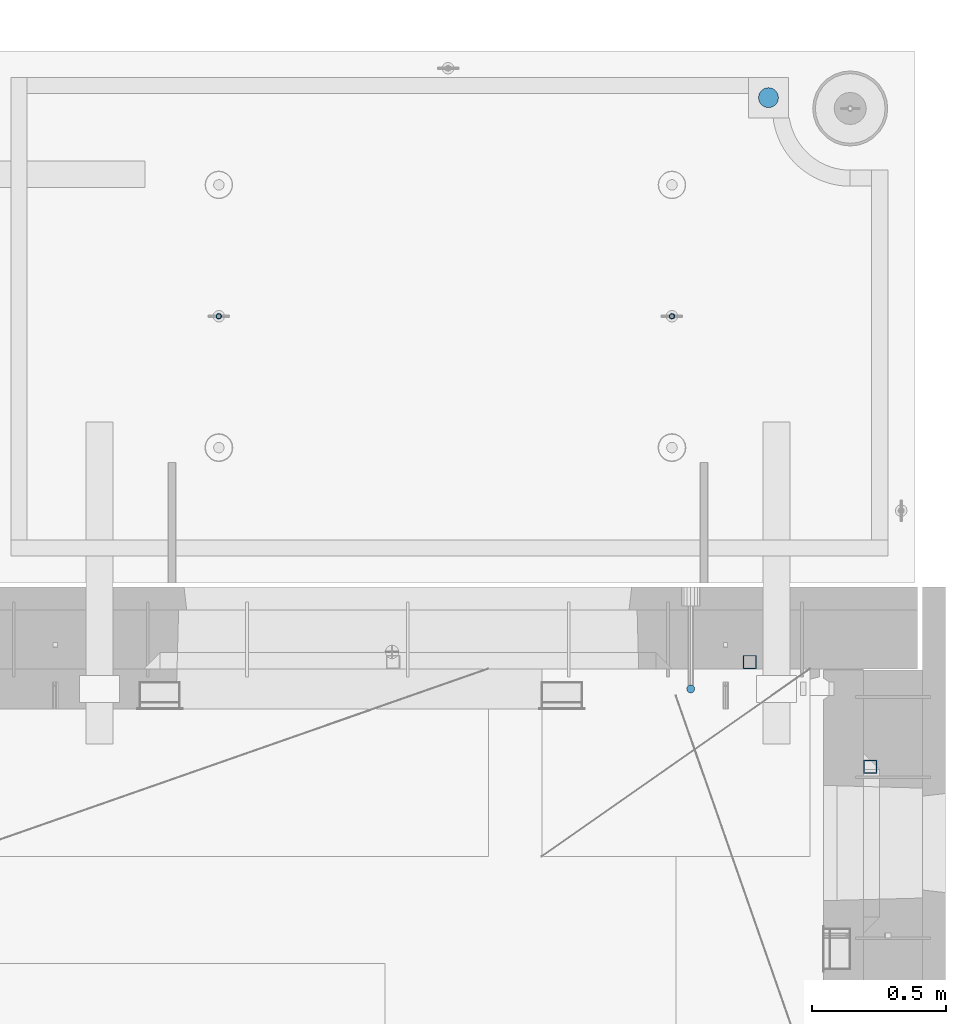
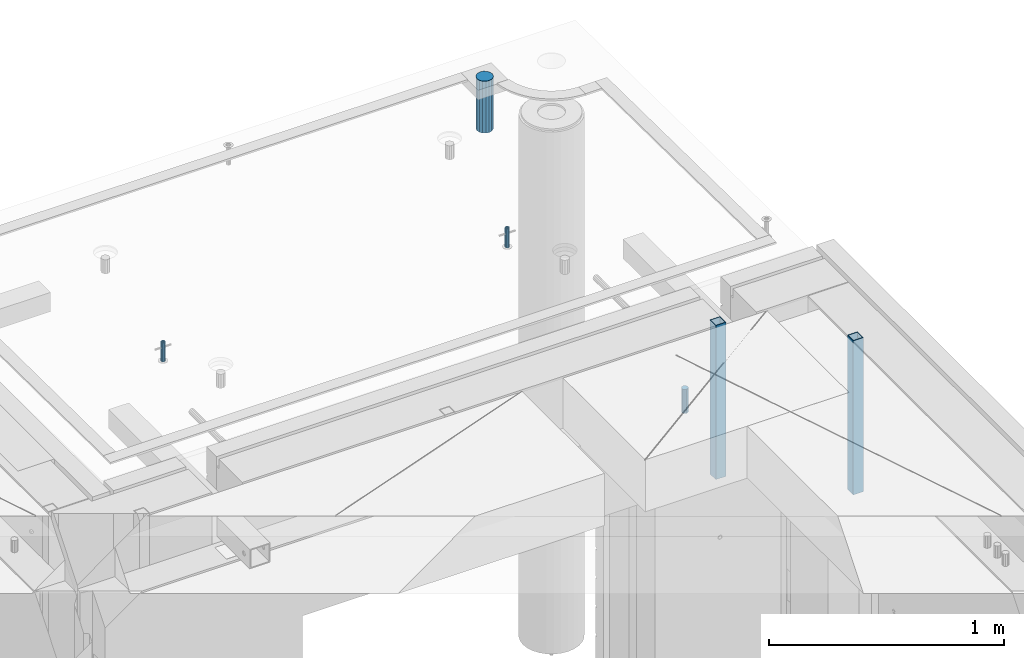
# One storey, part 37 of 349: 6 columns, 7 elements without a shape of their own.
"""IFC2X3 building model written with IfcOpenShell, lengths in millimetres."""

from ifc_helpers import new_model, si_unit, frame, origin_with_axes, place, context, subcontext, project, spatial, faceted_brep, material, type_object, element, aggregate, save


model = new_model("IFC2X3")

# Units and contexts
model_context = context("Model", 3, precision=1e-05, world=origin_with_axes())
body_context = subcontext(model_context, "Body", "Model", "MODEL_VIEW")
ifc_project = project(units=[si_unit("LENGTHUNIT", "METRE", prefix="MILLI"), si_unit("AREAUNIT", "SQUARE_METRE"), si_unit("VOLUMEUNIT", "CUBIC_METRE"), si_unit("MASSUNIT", "GRAM", prefix="KILO"), si_unit("TIMEUNIT", "SECOND"), si_unit("PLANEANGLEUNIT", "RADIAN"), si_unit("SOLIDANGLEUNIT", "STERADIAN"), si_unit("THERMODYNAMICTEMPERATUREUNIT", "DEGREE_CELSIUS"), si_unit("LUMINOUSINTENSITYUNIT", "LUMEN")], contexts=[model_context])

# Site, building, storey
site_placement = place(None, origin_with_axes())
site = spatial("IfcSite", under=ifc_project, at=site_placement, CompositionType="ELEMENT")
building_placement = place(site_placement, origin_with_axes())
building = spatial("IfcBuilding", under=site, at=building_placement, CompositionType="ELEMENT")
storey_placement = place(building_placement, origin_with_axes())
storey = spatial("IfcBuildingStorey", under=building, at=storey_placement, Name="4", CompositionType="ELEMENT", Elevation=0.0)

# Assemblies, columns
assembly_1_placement = place(storey_placement, origin_with_axes())
assembly_1 = element("IfcElementAssembly", 1, at=assembly_1_placement, inside=storey, AssemblyPlace="NOTDEFINED", PredefinedType="REINFORCEMENT_UNIT")
ifc_material_1 = material()
column_type_1 = type_object("IfcColumnType", Name="D30", PredefinedType="NOTDEFINED")
column_1_placement = place(assembly_1_placement, frame((34415.0073334623, 20504.9951872205, 93407.5), z_axis=(0.0, -1.0, 0.0), x_axis=(0.0, 0.0, 1.0)))
column_1 = element("IfcColumn", 2, at=column_1_placement, type_object=column_type_1, material=ifc_material_1, ObjectType="D30", context=body_context, shape_type="Brep", body=[
    faceted_brep([(0.0, -15.0, 0.0), (0.0, -12.9903810567666, -7.5), (125.0, -12.9903810567666, -7.5), (125.0, -15.0, 0.0), (0.0, -7.5, -12.9903810567666), (125.0, -7.5, -12.9903810567666), (0.0, 0.0, -15.0), (125.0, 0.0, -15.0), (0.0, 7.5, -12.9903810567666), (125.0, 7.5, -12.9903810567666), (0.0, 12.9903810567666, -7.5), (125.0, 12.9903810567666, -7.5), (0.0, 15.0, 0.0), (125.0, 15.0, 0.0), (0.0, 12.9903810567666, 7.5), (125.0, 12.9903810567666, 7.5), (0.0, 7.5, 12.9903810567666), (125.0, 7.5, 12.9903810567666), (0.0, 0.0, 15.0), (125.0, 0.0, 15.0), (0.0, -7.5, 12.9903810567666), (125.0, -7.5, 12.9903810567666), (0.0, -12.9903810567666, 7.5), (125.0, -12.9903810567666, 7.5)], [[[0, 1, 2, 3]], [[1, 4, 5, 2]], [[4, 6, 7, 5]], [[6, 8, 9, 7]], [[8, 10, 11, 9]], [[10, 12, 13, 11]], [[12, 14, 15, 13]], [[14, 16, 17, 15]], [[16, 18, 19, 17]], [[18, 20, 21, 19]], [[20, 22, 23, 21]], [[22, 0, 3, 23]], [[5, 7, 9, 11, 13, 15, 17, 19, 21, 23, 3, 2]], [[22, 20, 18, 16, 14, 12, 10, 8, 6, 4, 1, 0]]]),
])
assembly_2_placement = place(assembly_1_placement, origin_with_axes())
assembly_2 = element("IfcElementAssembly", 3, at=assembly_2_placement, Name="Steel Assembly", AssemblyPlace="NOTDEFINED", PredefinedType="RIGID_FRAME")
aggregate(assembly_1, [assembly_2, column_1])
ifc_material_2 = material(Name="STEEL/S355J2")
column_type_2 = type_object("IfcColumnType", Name="50X50X3", PredefinedType="NOTDEFINED")
column_2_placement = place(assembly_2_placement, frame((34635.0, 20605.0, 92940.0), z_axis=(1.0, 0.0, 0.0), x_axis=(0.0, 0.0, 1.0)))
column_2 = element("IfcColumn", 4, at=column_2_placement, type_object=column_type_2, material=ifc_material_2, ObjectType="50X50X3", context=body_context, shape_type="Brep", body=[
    faceted_brep([(0.0, 22.0, -22.0), (0.0, -22.0, -22.0), (800.0, -22.0, -22.0), (800.0, 22.0, -22.0), (0.0, -22.0, 22.0), (800.0, -22.0, 22.0), (0.0, 22.0, 22.0), (800.0, 22.0, 22.0), (0.0, 25.0, -25.0), (0.0, 25.0, 25.0), (800.0, 25.0, 25.0), (800.0, 25.0, -25.0), (0.0, -25.0, 25.0), (800.0, -25.0, 25.0), (0.0, -25.0, -25.0), (800.0, -25.0, -25.0)], [[[0, 1, 2, 3]], [[1, 4, 5, 2]], [[4, 6, 7, 5]], [[6, 0, 3, 7]], [[8, 9, 10, 11]], [[9, 12, 13, 10]], [[12, 14, 15, 13]], [[14, 8, 11, 15]], [[13, 15, 11, 10], [5, 7, 3, 2]], [[14, 12, 9, 8], [6, 4, 1, 0]]]),
])
aggregate(assembly_2, [column_2])

# Assemblies, column
assembly_3_placement = place(storey_placement, origin_with_axes())
assembly_3 = element("IfcElementAssembly", 5, at=assembly_3_placement, inside=storey, AssemblyPlace="NOTDEFINED", PredefinedType="REINFORCEMENT_UNIT")
assembly_4_placement = place(assembly_3_placement, origin_with_axes())
assembly_4 = element("IfcElementAssembly", 6, at=assembly_4_placement, Name="Steel Assembly", AssemblyPlace="NOTDEFINED", PredefinedType="RIGID_FRAME")
aggregate(assembly_3, [assembly_4])
column_3_placement = place(assembly_4_placement, frame((35085.0, 20215.0002861023, 92940.0), z_axis=(0.0, -1.0, 0.0), x_axis=(0.0, 0.0, 1.0)))
column_3 = element("IfcColumn", 7, at=column_3_placement, type_object=column_type_2, material=ifc_material_2, ObjectType="50X50X3", context=body_context, shape_type="Brep", body=[
    faceted_brep([(0.0, 22.0, -22.0), (0.0, -22.0, -22.0), (800.0, -22.0, -22.0), (800.0, 22.0, -22.0), (0.0, -22.0, 22.0), (800.0, -22.0, 22.0), (0.0, 22.0, 22.0), (800.0, 22.0, 22.0), (0.0, 25.0, -25.0), (0.0, 25.0, 25.0), (800.0, 25.0, 25.0), (800.0, 25.0, -25.0), (0.0, -25.0, 25.0), (800.0, -25.0, 25.0), (0.0, -25.0, -25.0), (800.0, -25.0, -25.0)], [[[0, 1, 2, 3]], [[1, 4, 5, 2]], [[4, 6, 7, 5]], [[6, 0, 3, 7]], [[8, 9, 10, 11]], [[9, 12, 13, 10]], [[12, 14, 15, 13]], [[14, 8, 11, 15]], [[13, 15, 11, 10], [5, 7, 3, 2]], [[14, 12, 9, 8], [6, 4, 1, 0]]]),
])
aggregate(assembly_4, [column_3])

# Assemblies, columns
assembly_5_placement = place(storey_placement, origin_with_axes())
assembly_5 = element("IfcElementAssembly", 8, at=assembly_5_placement, inside=storey, AssemblyPlace="NOTDEFINED", PredefinedType="REINFORCEMENT_UNIT")
assembly_6_placement = place(assembly_5_placement, origin_with_axes())
assembly_6 = element("IfcElementAssembly", 9, at=assembly_6_placement, Name="Steel Assembly", AssemblyPlace="NOTDEFINED", PredefinedType="RIGID_FRAME")
ifc_material_3 = material(Name="STEEL/1.4301")
column_type_3 = type_object("IfcColumnType", PredefinedType="NOTDEFINED")
column_4_placement = place(assembly_6_placement, frame((32654.9901431868, 21895.0034426477, 93445.0), z_axis=(0.000321686000089053, -0.999999948259057, 0.0), x_axis=(0.0, 0.0, 1.0)))
column_4 = element("IfcColumn", 10, at=column_4_placement, type_object=column_type_3, material=ifc_material_3, context=body_context, shape_type="Brep", body=[
    faceted_brep([(0.0, -8.0, 0.0), (0.0, -6.92820323027263, 4.0), (100.000000000029, -6.92820323027263, 4.0), (100.000000000029, -7.99999999999636, 0.0), (0.0, -4.0, 6.92820323027627), (100.000000000029, -4.0, 6.92820323027536), (0.0, 0.0, 8.0), (100.000000000029, 3.63797880709171e-12, 8.0), (0.0, 4.0, 6.92820323027627), (100.000000000029, 4.0, 6.92820323027536), (0.0, 6.92820323027263, 4.0), (100.000000000029, 6.92820323027627, 3.99999999999909), (0.0, 8.0, 0.0), (100.000000000029, 8.0, 0.0), (0.0, 6.92820323027263, -4.0), (100.000000000029, 6.92820323027627, -4.00000000000091), (0.0, 4.0, -6.92820323027627), (100.000000000029, 4.00000000000364, -6.92820323027536), (0.0, 0.0, -8.0), (100.000000000029, 3.63797880709171e-12, -8.00000000000091), (0.0, -4.0, -6.92820323027627), (100.000000000029, -3.99999999999636, -6.92820323027627), (0.0, -6.92820323027263, -4.0), (100.000000000029, -6.92820323027263, -4.0), (0.0, -10.4999999999927, -1.45519152283669e-11), (0.0, -9.09326673972828, -5.25000000001455), (100.000000000262, -9.09326673972828, -5.25000000001455), (100.000000000262, -10.4999999999927, -1.45519152283669e-11), (0.0, -5.24999999998545, -9.09326673974283), (100.000000000262, -5.24999999998545, -9.09326673974283), (0.0, 7.27595761418343e-12, -10.5), (100.000000000262, 7.27595761418343e-12, -10.5), (0.0, 5.25000000001455, -9.09326673975738), (100.000000000262, 5.25000000001455, -9.09326673975738), (0.0, 9.09326673975011, -5.25000000001455), (100.000000000262, 9.09326673975011, -5.25000000001455), (0.0, 10.5000000000073, -1.45519152283669e-11), (100.000000000262, 10.5000000000073, -1.45519152283669e-11), (0.0, 9.09326673975011, 5.25), (100.000000000262, 9.09326673975011, 5.25), (0.0, 5.25000000000728, 9.09326673972828), (100.000000000262, 5.25000000000728, 9.09326673972828), (0.0, 1.45519152283669e-11, 10.4999999999854), (100.000000000262, 1.45519152283669e-11, 10.4999999999854), (0.0, -5.24999999999272, 9.09326673972828), (100.000000000262, -5.24999999999272, 9.09326673972828), (0.0, -9.09326673972828, 5.24999999998545), (100.000000000262, -9.09326673972828, 5.24999999998545)], [[[0, 1, 2, 3]], [[1, 4, 5, 2]], [[4, 6, 7, 5]], [[6, 8, 9, 7]], [[8, 10, 11, 9]], [[10, 12, 13, 11]], [[12, 14, 15, 13]], [[14, 16, 17, 15]], [[16, 18, 19, 17]], [[18, 20, 21, 19]], [[20, 22, 23, 21]], [[22, 0, 3, 23]], [[24, 25, 26, 27]], [[25, 28, 29, 26]], [[28, 30, 31, 29]], [[30, 32, 33, 31]], [[32, 34, 35, 33]], [[34, 36, 37, 35]], [[36, 38, 39, 37]], [[38, 40, 41, 39]], [[40, 42, 43, 41]], [[42, 44, 45, 43]], [[44, 46, 47, 45]], [[46, 24, 27, 47]], [[29, 31, 33, 35, 37, 39, 41, 43, 45, 47, 27, 26], [5, 7, 9, 11, 13, 15, 17, 19, 21, 23, 3, 2]], [[46, 44, 42, 40, 38, 36, 34, 32, 30, 28, 25, 24], [22, 20, 18, 16, 14, 12, 10, 8, 6, 4, 1, 0]]]),
])
aggregate(assembly_6, [column_4])
assembly_7_placement = place(assembly_5_placement, origin_with_axes())
assembly_7 = element("IfcElementAssembly", 11, at=assembly_7_placement, Name="Steel Assembly", AssemblyPlace="NOTDEFINED", PredefinedType="RIGID_FRAME")
column_5_placement = place(assembly_7_placement, frame((34345.0001431868, 21895.0034426477, 93445.0), z_axis=(0.000321686000089053, -0.999999948259057, 0.0), x_axis=(0.0, 0.0, 1.0)))
column_5 = element("IfcColumn", 12, at=column_5_placement, type_object=column_type_3, material=ifc_material_3, context=body_context, shape_type="Brep", body=[
    faceted_brep([(0.0, -8.0, 0.0), (0.0, -6.92820323027263, 4.0), (100.000000000029, -6.92820323027263, 4.0), (100.000000000029, -7.99999999999636, 0.0), (0.0, -4.0, 6.92820323027627), (100.000000000029, -4.0, 6.92820323027536), (0.0, 0.0, 8.0), (100.000000000029, 3.63797880709171e-12, 8.0), (0.0, 4.0, 6.92820323027627), (100.000000000029, 4.0, 6.92820323027536), (0.0, 6.92820323027263, 4.0), (100.000000000029, 6.92820323027627, 3.99999999999909), (0.0, 8.0, 0.0), (100.000000000029, 8.0, 0.0), (0.0, 6.92820323027263, -4.0), (100.000000000029, 6.92820323027627, -4.00000000000091), (0.0, 4.0, -6.92820323027627), (100.000000000029, 4.00000000000364, -6.92820323027536), (0.0, 0.0, -8.0), (100.000000000029, 3.63797880709171e-12, -8.00000000000091), (0.0, -4.0, -6.92820323027627), (100.000000000029, -3.99999999999636, -6.92820323027627), (0.0, -6.92820323027263, -4.0), (100.000000000029, -6.92820323027263, -4.0), (0.0, -10.4999999999927, -1.45519152283669e-11), (0.0, -9.09326673972828, -5.25000000001455), (100.000000000262, -9.09326673972828, -5.25000000001455), (100.000000000262, -10.4999999999927, -1.45519152283669e-11), (0.0, -5.24999999998545, -9.09326673974283), (100.000000000262, -5.24999999998545, -9.09326673974283), (0.0, 7.27595761418343e-12, -10.5), (100.000000000262, 7.27595761418343e-12, -10.5), (0.0, 5.25000000001455, -9.09326673975738), (100.000000000262, 5.25000000001455, -9.09326673975738), (0.0, 9.09326673975011, -5.25000000001455), (100.000000000262, 9.09326673975011, -5.25000000001455), (0.0, 10.5000000000073, -1.45519152283669e-11), (100.000000000262, 10.5000000000073, -1.45519152283669e-11), (0.0, 9.09326673975011, 5.25), (100.000000000262, 9.09326673975011, 5.25), (0.0, 5.25000000000728, 9.09326673972828), (100.000000000262, 5.25000000000728, 9.09326673972828), (0.0, 1.45519152283669e-11, 10.4999999999854), (100.000000000262, 1.45519152283669e-11, 10.4999999999854), (0.0, -5.24999999999272, 9.09326673972828), (100.000000000262, -5.24999999999272, 9.09326673972828), (0.0, -9.09326673972828, 5.24999999998545), (100.000000000262, -9.09326673972828, 5.24999999998545)], [[[0, 1, 2, 3]], [[1, 4, 5, 2]], [[4, 6, 7, 5]], [[6, 8, 9, 7]], [[8, 10, 11, 9]], [[10, 12, 13, 11]], [[12, 14, 15, 13]], [[14, 16, 17, 15]], [[16, 18, 19, 17]], [[18, 20, 21, 19]], [[20, 22, 23, 21]], [[22, 0, 3, 23]], [[24, 25, 26, 27]], [[25, 28, 29, 26]], [[28, 30, 31, 29]], [[30, 32, 33, 31]], [[32, 34, 35, 33]], [[34, 36, 37, 35]], [[36, 38, 39, 37]], [[38, 40, 41, 39]], [[40, 42, 43, 41]], [[42, 44, 45, 43]], [[44, 46, 47, 45]], [[46, 24, 27, 47]], [[29, 31, 33, 35, 37, 39, 41, 43, 45, 47, 27, 26], [5, 7, 9, 11, 13, 15, 17, 19, 21, 23, 3, 2]], [[46, 44, 42, 40, 38, 36, 34, 32, 30, 28, 25, 24], [22, 20, 18, 16, 14, 12, 10, 8, 6, 4, 1, 0]]]),
])
aggregate(assembly_7, [column_5])
ifc_material_4 = material()
column_type_4 = type_object("IfcColumnType", Name="D75", PredefinedType="NOTDEFINED")
column_6_placement = place(assembly_5_placement, frame((34704.9998568133, 22710.1651093338, 93440.0), z_axis=(0.9999999949993, 0.000100007000000845, 0.0), x_axis=(0.0, 0.0, 1.0)))
column_6 = element("IfcColumn", 13, at=column_6_placement, type_object=column_type_4, material=ifc_material_4, ObjectType="D75", context=body_context, shape_type="Brep", body=[
    faceted_brep([(0.0, -37.4999999999991, 1.81898940354586e-12), (0.0, -34.6454824691718, -14.3506287136888), (270.0, -34.6454824691718, -14.3506287136888), (270.0, -37.4999999999991, 1.81898940354586e-12), (0.0, -26.5165042944936, -26.5165042944936), (270.0, -26.5165042944936, -26.5165042944936), (0.0, -14.3506287136906, -34.6454824691718), (270.0, -14.3506287136906, -34.6454824691718), (0.0, 9.09494701772928e-13, -37.4999999999982), (270.0, 9.09494701772928e-13, -37.4999999999982), (0.0, 14.3506287136915, -34.6454824691718), (270.0, 14.3506287136915, -34.6454824691718), (0.0, 26.5165042944973, -26.5165042944927), (270.0, 26.5165042944973, -26.5165042944927), (0.0, 34.6454824691746, -14.3506287136897), (270.0, 34.6454824691746, -14.3506287136897), (0.0, 37.5000000000018, 1.81898940354586e-12), (270.0, 37.5000000000018, 1.81898940354586e-12), (0.0, 34.6454824691755, 14.3506287136925), (270.0, 34.6454824691755, 14.3506287136925), (0.0, 26.5165042944964, 26.5165042944973), (270.0, 26.5165042944964, 26.5165042944973), (0.0, 14.3506287136934, 34.6454824691755), (270.0, 14.3506287136934, 34.6454824691755), (0.0, 1.81898940354586e-12, 37.5000000000027), (270.0, 1.81898940354586e-12, 37.5000000000027), (0.0, -14.3506287136897, 34.6454824691746), (270.0, -14.3506287136897, 34.6454824691746), (0.0, -26.5165042944946, 26.5165042944973), (270.0, -26.5165042944946, 26.5165042944973), (0.0, -34.6454824691718, 14.3506287136925), (270.0, -34.6454824691718, 14.3506287136925)], [[[0, 1, 2, 3]], [[1, 4, 5, 2]], [[4, 6, 7, 5]], [[6, 8, 9, 7]], [[8, 10, 11, 9]], [[10, 12, 13, 11]], [[12, 14, 15, 13]], [[14, 16, 17, 15]], [[16, 18, 19, 17]], [[18, 20, 21, 19]], [[20, 22, 23, 21]], [[22, 24, 25, 23]], [[24, 26, 27, 25]], [[26, 28, 29, 27]], [[28, 30, 31, 29]], [[30, 0, 3, 31]], [[5, 7, 9, 11, 13, 15, 17, 19, 21, 23, 25, 27, 29, 31, 3, 2]], [[30, 28, 26, 24, 22, 20, 18, 16, 14, 12, 10, 8, 6, 4, 1, 0]]]),
])
aggregate(assembly_5, [assembly_6, assembly_7, column_6])

save(model, "model.ifc")
